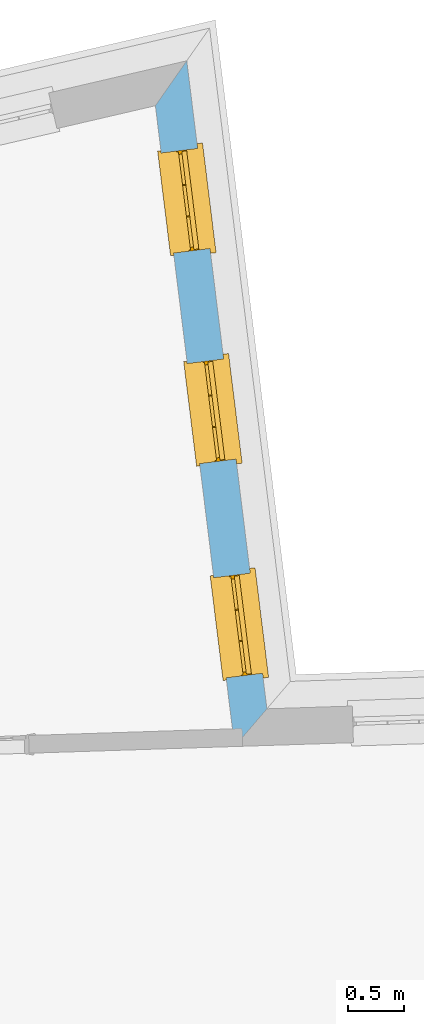
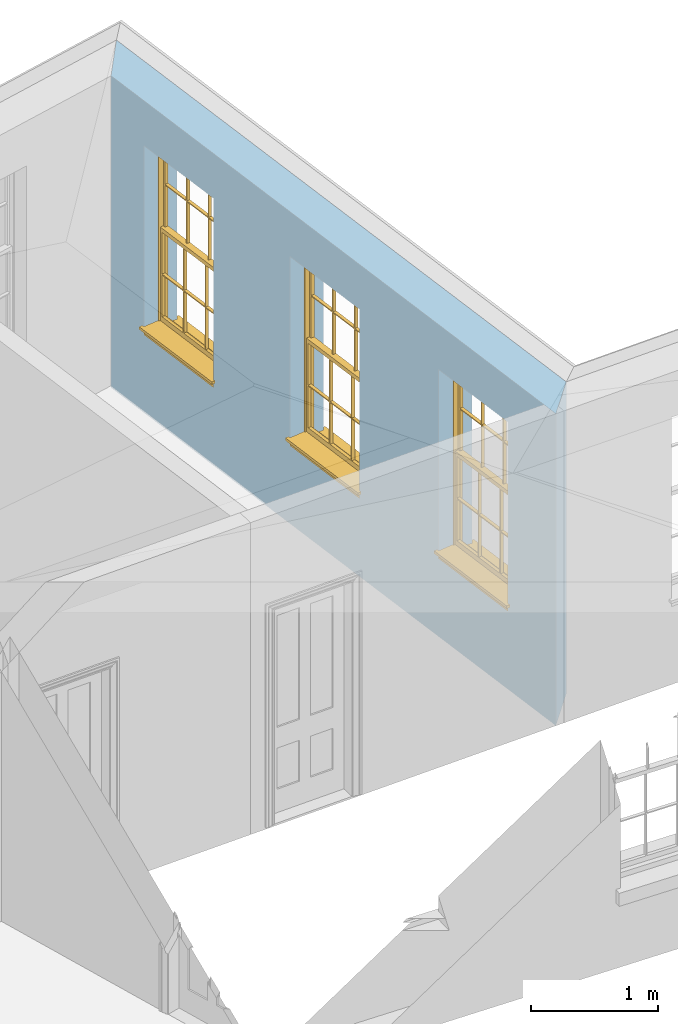
# One storey, part 9 of 11: 3 windows, 3 openings, plus 1 element that does not belong to this part.
"""IFC2X3 building model written with IfcOpenShell, lengths in metres."""

from ifc_helpers import new_model, si_unit, frame, origin, place, context, subcontext, project, spatial, polyline, outline, extrude, faceted_brep, material, layer, layer_set, layer_usage, element, fill, save


model = new_model("IFC2X3")

# Units and contexts
model_context = context("Model", 3, world=origin())
body_context = subcontext(model_context, "Body", "Model", "MODEL_VIEW")
ifc_project = project(units=[si_unit("PLANEANGLEUNIT", "RADIAN"), si_unit("MASSUNIT", "GRAM", prefix="KILO"), si_unit("FORCEUNIT", "NEWTON", prefix="KILO"), si_unit("LENGTHUNIT", "METRE")], contexts=[model_context])

# Site, building, storey
site_placement = place(None, origin())
site = spatial("IfcSite", under=ifc_project, at=site_placement, CompositionType="ELEMENT")
building_placement = place(None, origin())
building = spatial("IfcBuilding", under=site, at=building_placement, Name="Building plot-10", CompositionType="ELEMENT")
storey_placement = place(None, frame((0.0, 0.0, 4.6)))
storey = spatial("IfcBuildingStorey", under=building, at=storey_placement, Name="Floor 1", CompositionType="ELEMENT", Elevation=4.6)

# Wall, openings, windows
ifc_material = material(Name="Masonry")
ifc_layer = layer(ifc_material, 0.33, ventilated=False)
ifc_layer_set = layer_set([ifc_layer], Name="My Wall")
ifc_layer_usage = layer_usage(ifc_layer_set, "AXIS2", "NEGATIVE", 0.08)
wall_placement = place(storey_placement, origin())
wall = element("IfcWallStandardCase", 1, at=wall_placement, inside=storey, material=ifc_layer_usage, Name="exterior", context=body_context, shape_type="SweptSolid", body=[
    extrude(outline(polyline([(50.4938484504191, 20.0843374826447), (50.7843534970595, 20.4239768335759), (50.0623886340856, 26.2609056783057), (49.7798970152204, 25.8564795072323), (50.4938484504191, 20.0843374826447)])), origin(), (0.0, 0.0, 1.0), 3.0),
])
opening_1_placement = place(storey_placement, frame((0.0, 0.0, 0.75)))
opening_1 = element("IfcOpeningElement", 2, at=opening_1_placement, cuts=wall, Name="Opening", ObjectType="Opening", context=body_context, shape_type="SweptSolid", body=[
    extrude(outline(polyline([(50.7448686581057, 20.7432031661003), (50.6331627679987, 21.6463209846131), (50.3056585041424, 21.6058122552337), (50.4173643942494, 20.7026944367208), (50.7448686581057, 20.7432031661003)])), origin(), (0.0, 0.0, 1.0), 1.82),
])
opening_2_placement = place(storey_placement, frame((0.0, 0.0, 0.75)))
opening_2 = element("IfcOpeningElement", 3, at=opening_2_placement, cuts=wall, Name="Opening", ObjectType="Opening", context=body_context, shape_type="SweptSolid", body=[
    extrude(outline(polyline([(50.5062372966536, 22.6724858062268), (50.3945314065466, 23.5756036247397), (50.0670271426903, 23.5350948953602), (50.1787330327973, 22.6319770768474), (50.5062372966536, 22.6724858062268)])), origin(), (0.0, 0.0, 1.0), 1.82),
])
opening_3_placement = place(storey_placement, frame((0.0, 0.0, 0.75)))
opening_3 = element("IfcOpeningElement", 4, at=opening_3_placement, cuts=wall, Name="Opening", ObjectType="Opening", context=body_context, shape_type="SweptSolid", body=[
    extrude(outline(polyline([(50.2716577484948, 24.5690104173997), (50.1599518583878, 25.4721282359125), (49.8324475945315, 25.4316195065331), (49.9441534846385, 24.5285016880202), (50.2716577484948, 24.5690104173997)])), origin(), (0.0, 0.0, 1.0), 1.82),
])
window_1_placement = place(storey_placement, frame((50.4967593673055, 20.7125147347522, 0.75), z_axis=(0.0, 0.0, 1.0), x_axis=(-0.111705890107025, 0.903117818512843, 0.0)))
window_1 = element("IfcWindow", 5, at=window_1_placement, inside=storey, Name="bedroom outside window", OverallHeight=1.82, OverallWidth=0.91, context=body_context, shape_type="Brep", held_by="IfcProductRepresentation", body=[
    faceted_brep([(0.033125, -0.105, 0.975209), (0.01, -0.105, 0.975209), (0.033125, -0.105, 1.376042), (0.876875, -0.105, 0.975209), (0.876875, -0.105, 1.376042), (0.9, -0.105, 0.975209), (0.876875, -0.105, 1.386042), (0.876875, -0.105, 1.786875), (0.9, -0.105, 1.81), (0.033125, -0.105, 1.786875), (0.033125, -0.105, 1.386042), (0.01, -0.105, 1.81), (0.876875, -0.135, 1.376042), (0.876875, -0.135, 0.975209), (0.9, -0.135, 0.937083), (0.033125, -0.135, 1.786875), (0.01, -0.135, 1.81), (0.033125, -0.135, 1.386042), (0.01, -0.135, 0.937083), (0.033125, -0.135, 0.975209), (0.033125, -0.135, 1.376042), (0.876875, -0.135, 1.786875), (0.876875, -0.135, 1.386042), (0.9, -0.135, 1.81), (0.033125, -0.105, 0.937083), (0.01, -0.105, 0.937083), (0.033125, -0.105, 0.53625), (0.876875, -0.105, 0.937083), (0.876875, -0.105, 0.53625), (0.9, -0.105, 0.937083), (0.876875, -0.105, 0.52625), (0.876875, -0.105, 0.125417), (0.9, -0.105, 0.077167), (0.033125, -0.105, 0.125417), (0.033125, -0.105, 0.52625), (0.01, -0.105, 0.077167), (-0.0425, -0.25, 0.01), (-0.0425, -0.3, 0.001667), (0.0, -0.25, 0.01), (0.9525, -0.25, 0.01), (0.91, -0.25, 0.01), (0.9525, -0.3, 0.001667), (-0.02, 0.08, 0.077167), (0.0, 0.08, 0.077167), (-0.02, 0.11, 0.077167), (0.0, -0.06, 0.077167), (0.01, -0.06, 0.077167), (0.91, -0.06, 0.077167), (0.91, 0.08, 0.077167), (0.9, -0.06, 0.077167), (0.93, 0.08, 0.077167), (0.93, 0.11, 0.077167), (0.01, -0.075, 0.975209), (0.9, -0.075, 0.975209), (0.876875, -0.075, 0.125417), (0.876875, -0.075, 0.52625), (0.9, -0.075, 0.077167), (0.876875, -0.075, 0.53625), (0.876875, -0.075, 0.937083), (0.033125, -0.075, 0.125417), (0.01, -0.075, 0.077167), (0.033125, -0.075, 0.52625), (0.033125, -0.075, 0.937083), (0.033125, -0.075, 0.53625), (-0.02, 0.08, 0.052167), (-0.02, 0.11, 0.052167), (0.93, 0.11, 0.052167), (0.93, 0.08, 0.052167), (0.91, 0.08, 0.052167), (0.0, 0.08, 0.052167), (0.91, -0.15, 0.026667), (0.0, -0.15, 0.026667), (-0.0425, -0.3, -0.123333), (0.9525, -0.3, -0.123333), (-0.0425, -0.25, -0.123333), (0.9525, -0.25, -0.123333), (0.01, -0.06, 1.81), (0.9, -0.06, 1.81), (0.0, -0.06, 1.82), (0.91, -0.06, 1.82), (0.01, -0.15, 0.077167), (0.9, -0.15, 0.077167), (0.592292, -0.105, 0.125417), (0.592292, -0.075, 0.125417), (0.317708, -0.075, 0.125417), (0.317708, -0.105, 0.125417), (0.592292, -0.105, 0.53625), (0.317708, -0.105, 0.53625), (0.317708, -0.105, 0.52625), (0.592292, -0.105, 0.52625), (0.592292, -0.075, 0.53625), (0.317708, -0.075, 0.53625), (0.592292, -0.135, 1.386042), (0.592292, -0.105, 1.386042), (0.317708, -0.105, 1.386042), (0.317708, -0.135, 1.386042), (0.317708, -0.135, 1.376042), (0.592292, -0.135, 1.376042), (0.317708, -0.105, 1.376042), (0.592292, -0.105, 1.376042), (0.602292, -0.135, 1.376042), (0.592292, -0.135, 0.975209), (0.602292, -0.135, 0.975209), (0.602292, -0.105, 0.975209), (0.592292, -0.105, 0.975209), (0.602292, -0.105, 1.376042), (0.602292, -0.075, 0.53625), (0.602292, -0.105, 0.53625), (0.317708, -0.075, 0.52625), (0.307708, -0.075, 0.125417), (0.307708, -0.075, 0.52625), (0.602292, -0.075, 0.52625), (0.602292, -0.075, 0.125417), (0.592292, -0.075, 0.52625), (0.307708, -0.075, 0.53625), (0.317708, -0.075, 0.937083), (0.307708, -0.075, 0.937083), (0.602292, -0.075, 0.937083), (0.592292, -0.075, 0.937083), (0.307708, -0.105, 0.52625), (0.307708, -0.105, 0.125417), (0.307708, -0.105, 0.53625), (0.307708, -0.105, 0.937083), (0.592292, -0.105, 0.937083), (0.317708, -0.105, 0.937083), (0.602292, -0.105, 0.937083), (0.602292, -0.105, 0.52625), (0.602292, -0.105, 0.125417), (0.307708, -0.135, 1.386042), (0.307708, -0.135, 1.376042), (0.307708, -0.135, 0.975209), (0.317708, -0.135, 0.975209), (0.317708, -0.135, 1.786875), (0.307708, -0.135, 1.786875), (0.602292, -0.135, 1.786875), (0.592292, -0.135, 1.786875), (0.602292, -0.135, 1.386042), (0.602292, -0.105, 1.386042), (0.307708, -0.105, 1.386042), (0.307708, -0.105, 1.786875), (0.317708, -0.105, 1.786875), (0.592292, -0.105, 1.786875), (0.602292, -0.105, 1.786875), (0.307708, -0.105, 1.376042), (0.317708, -0.105, 0.975209), (0.307708, -0.105, 0.975209), (0.91, -0.15, 1.82), (0.9, -0.15, 1.81), (0.01, -0.15, 1.81), (0.0, -0.15, 1.82), (0.91, -0.25, 0.0), (0.0, -0.25, 0.0), (0.91, 0.08, 0.0), (0.0, 0.08, 0.0)], [[[0, 1, 2]], [[3, 4, 5]], [[6, 7, 8]], [[9, 10, 11]], [[12, 13, 14]], [[15, 16, 17]], [[18, 19, 20]], [[21, 22, 23]], [[24, 25, 26]], [[27, 28, 29]], [[30, 31, 32]], [[33, 34, 35]], [[14, 27, 29]], [[25, 24, 18]], [[36, 37, 38]], [[39, 40, 41]], [[42, 43, 44]], [[45, 46, 43]], [[47, 48, 49]], [[50, 51, 48]], [[1, 0, 52]], [[5, 53, 3]], [[54, 55, 56]], [[57, 58, 53]], [[59, 60, 61]], [[62, 63, 52]], [[48, 43, 46, 49]], [[51, 44, 43, 48]], [[64, 42, 44, 65]], [[65, 44, 51, 66]], [[66, 51, 50, 67]], [[65, 66, 68, 69]], [[60, 56, 49, 46]], [[70, 71, 38, 40]], [[37, 41, 40, 38]], [[37, 72, 73, 41]], [[74, 75, 73, 72]], [[8, 11, 76, 77]], [[76, 78, 79, 77]], [[32, 35, 80, 81]], [[81, 80, 71, 70]], [[82, 83, 84, 85]], [[86, 87, 88, 89]], [[86, 90, 91, 87]], [[92, 93, 94, 95]], [[92, 95, 96, 97]], [[96, 98, 99, 97]], [[100, 97, 101, 102]], [[103, 104, 99, 105]], [[97, 99, 104, 101]], [[102, 103, 105, 100]], [[28, 57, 106, 107]], [[108, 84, 109, 110]], [[111, 112, 83, 113]], [[114, 110, 61, 63]], [[90, 113, 108, 91]], [[115, 91, 114, 116]], [[117, 106, 90, 118]], [[111, 106, 57, 55]], [[119, 110, 109, 120]], [[34, 61, 110, 119]], [[89, 113, 83, 82]], [[88, 108, 113, 89]], [[85, 84, 108, 88]], [[121, 114, 63, 26]], [[122, 116, 114, 121]], [[123, 118, 90, 86]], [[87, 91, 115, 124]], [[107, 106, 117, 125]], [[126, 111, 55, 30]], [[127, 112, 111, 126]], [[126, 30, 28, 107]], [[88, 119, 120, 85]], [[126, 89, 82, 127]], [[125, 123, 86, 107]], [[121, 26, 34, 119]], [[124, 122, 121, 87]], [[128, 17, 20, 129]], [[96, 129, 130, 131]], [[132, 133, 128, 95]], [[134, 135, 92, 136]], [[100, 12, 22, 136]], [[137, 6, 4, 105]], [[94, 138, 139, 140]], [[137, 93, 141, 142]], [[99, 98, 94, 93]], [[143, 2, 10, 138]], [[144, 145, 143, 98]], [[129, 143, 145, 130]], [[20, 2, 143, 129]], [[131, 144, 98, 96]], [[128, 138, 10, 17]], [[133, 139, 138, 128]], [[135, 141, 93, 92]], [[95, 94, 140, 132]], [[22, 6, 137, 136]], [[136, 137, 142, 134]], [[100, 105, 4, 12]], [[107, 86, 89, 126]], [[106, 111, 113, 90]], [[91, 108, 110, 114]], [[87, 121, 119, 88]], [[97, 100, 136, 92]], [[129, 96, 95, 128]], [[98, 143, 138, 94]], [[105, 99, 93, 137]], [[131, 101, 104, 144]], [[124, 115, 118, 123]], [[132, 140, 141, 135]], [[120, 109, 59, 33]], [[15, 9, 139, 133]], [[134, 142, 7, 21]], [[31, 54, 112, 127]], [[36, 74, 72, 37]], [[39, 41, 73, 75]], [[18, 14, 101, 131]], [[23, 16, 132, 135]], [[83, 56, 60, 84]], [[52, 53, 118, 115]], [[53, 52, 144, 104]], [[11, 8, 141, 140]], [[14, 18, 124, 123]], [[2, 1, 11, 10]], [[8, 5, 4, 6]], [[57, 53, 56, 55]], [[60, 52, 63, 61]], [[26, 25, 35, 34]], [[32, 29, 28, 30]], [[14, 23, 22, 12]], [[18, 20, 17, 16]], [[19, 0, 2, 20]], [[17, 10, 9, 15]], [[12, 4, 3, 13]], [[21, 7, 6, 22]], [[27, 58, 57, 28]], [[30, 55, 54, 31]], [[33, 59, 61, 34]], [[26, 63, 62, 24]], [[5, 8, 77, 53]], [[76, 11, 1, 52]], [[46, 45, 78, 76]], [[49, 77, 79, 47]], [[70, 146, 147, 81]], [[71, 80, 148, 149]], [[19, 130, 145, 0]], [[102, 13, 3, 103]], [[116, 122, 24, 62]], [[29, 32, 81, 14]], [[80, 35, 25, 18]], [[60, 46, 76, 52]], [[77, 49, 56, 53]], [[23, 14, 81, 147]], [[16, 148, 80, 18]], [[35, 85, 120]], [[120, 33, 35]], [[127, 82, 32]], [[32, 31, 127]], [[32, 82, 85, 35]], [[102, 101, 14]], [[14, 13, 102]], [[18, 131, 130]], [[130, 19, 18]], [[134, 21, 23]], [[23, 135, 134]], [[16, 15, 133]], [[133, 132, 16]], [[11, 140, 139]], [[139, 9, 11]], [[142, 141, 8]], [[8, 7, 142]], [[23, 147, 148, 16]], [[146, 149, 148, 147]], [[52, 115, 116]], [[116, 62, 52]], [[118, 53, 117]], [[58, 117, 53]], [[27, 125, 117, 58]], [[56, 83, 112]], [[112, 54, 56]], [[109, 84, 60]], [[60, 59, 109]], [[125, 27, 14]], [[14, 123, 125]], [[122, 124, 18]], [[18, 24, 122]], [[145, 144, 52]], [[52, 0, 145]], [[103, 3, 53]], [[53, 104, 103]], [[79, 78, 149, 146]], [[78, 45, 71, 149]], [[146, 70, 47, 79]], [[150, 75, 74, 151]], [[68, 66, 67]], [[48, 68, 67, 50]], [[69, 64, 65]], [[42, 64, 69, 43]], [[69, 68, 152, 153]], [[70, 68, 48, 47]], [[150, 152, 68, 70]], [[43, 69, 71, 45]], [[69, 153, 151, 71]], [[152, 150, 151, 153]], [[38, 151, 74, 36]], [[71, 151, 38]], [[39, 75, 150, 40]], [[40, 150, 70]]]),
])
fill(opening_1, window_1)
window_2_placement = place(storey_placement, frame((50.2581280058534, 22.6417973748787, 0.75), z_axis=(0.0, 0.0, 1.0), x_axis=(-0.111705890107025, 0.903117818512843, 0.0)))
window_2 = element("IfcWindow", 6, at=window_2_placement, inside=storey, Name="bedroom outside window", OverallHeight=1.82, OverallWidth=0.91, context=body_context, shape_type="Brep", held_by="IfcProductRepresentation", body=[
    faceted_brep([(0.033125, -0.105, 0.975209), (0.01, -0.105, 0.975209), (0.033125, -0.105, 1.376042), (0.876875, -0.105, 0.975209), (0.876875, -0.105, 1.376042), (0.9, -0.105, 0.975209), (0.876875, -0.105, 1.386042), (0.876875, -0.105, 1.786875), (0.9, -0.105, 1.81), (0.033125, -0.105, 1.786875), (0.033125, -0.105, 1.386042), (0.01, -0.105, 1.81), (0.876875, -0.135, 1.376042), (0.876875, -0.135, 0.975209), (0.9, -0.135, 0.937083), (0.033125, -0.135, 1.786875), (0.01, -0.135, 1.81), (0.033125, -0.135, 1.386042), (0.01, -0.135, 0.937083), (0.033125, -0.135, 0.975209), (0.033125, -0.135, 1.376042), (0.876875, -0.135, 1.786875), (0.876875, -0.135, 1.386042), (0.9, -0.135, 1.81), (0.033125, -0.105, 0.937083), (0.01, -0.105, 0.937083), (0.033125, -0.105, 0.53625), (0.876875, -0.105, 0.937083), (0.876875, -0.105, 0.53625), (0.9, -0.105, 0.937083), (0.876875, -0.105, 0.52625), (0.876875, -0.105, 0.125417), (0.9, -0.105, 0.077167), (0.033125, -0.105, 0.125417), (0.033125, -0.105, 0.52625), (0.01, -0.105, 0.077167), (-0.0425, -0.25, 0.01), (-0.0425, -0.3, 0.001667), (0.0, -0.25, 0.01), (0.9525, -0.25, 0.01), (0.91, -0.25, 0.01), (0.9525, -0.3, 0.001667), (-0.02, 0.08, 0.077167), (0.0, 0.08, 0.077167), (-0.02, 0.11, 0.077167), (0.0, -0.06, 0.077167), (0.01, -0.06, 0.077167), (0.91, -0.06, 0.077167), (0.91, 0.08, 0.077167), (0.9, -0.06, 0.077167), (0.93, 0.08, 0.077167), (0.93, 0.11, 0.077167), (0.01, -0.075, 0.975209), (0.9, -0.075, 0.975209), (0.876875, -0.075, 0.125417), (0.876875, -0.075, 0.52625), (0.9, -0.075, 0.077167), (0.876875, -0.075, 0.53625), (0.876875, -0.075, 0.937083), (0.033125, -0.075, 0.125417), (0.01, -0.075, 0.077167), (0.033125, -0.075, 0.52625), (0.033125, -0.075, 0.937083), (0.033125, -0.075, 0.53625), (-0.02, 0.08, 0.052167), (-0.02, 0.11, 0.052167), (0.93, 0.11, 0.052167), (0.93, 0.08, 0.052167), (0.91, 0.08, 0.052167), (0.0, 0.08, 0.052167), (0.91, -0.15, 0.026667), (0.0, -0.15, 0.026667), (-0.0425, -0.3, -0.123333), (0.9525, -0.3, -0.123333), (-0.0425, -0.25, -0.123333), (0.9525, -0.25, -0.123333), (0.01, -0.06, 1.81), (0.9, -0.06, 1.81), (0.0, -0.06, 1.82), (0.91, -0.06, 1.82), (0.01, -0.15, 0.077167), (0.9, -0.15, 0.077167), (0.592292, -0.105, 0.125417), (0.592292, -0.075, 0.125417), (0.317708, -0.075, 0.125417), (0.317708, -0.105, 0.125417), (0.592292, -0.105, 0.53625), (0.317708, -0.105, 0.53625), (0.317708, -0.105, 0.52625), (0.592292, -0.105, 0.52625), (0.592292, -0.075, 0.53625), (0.317708, -0.075, 0.53625), (0.592292, -0.135, 1.386042), (0.592292, -0.105, 1.386042), (0.317708, -0.105, 1.386042), (0.317708, -0.135, 1.386042), (0.317708, -0.135, 1.376042), (0.592292, -0.135, 1.376042), (0.317708, -0.105, 1.376042), (0.592292, -0.105, 1.376042), (0.602292, -0.135, 1.376042), (0.592292, -0.135, 0.975209), (0.602292, -0.135, 0.975209), (0.602292, -0.105, 0.975209), (0.592292, -0.105, 0.975209), (0.602292, -0.105, 1.376042), (0.602292, -0.075, 0.53625), (0.602292, -0.105, 0.53625), (0.317708, -0.075, 0.52625), (0.307708, -0.075, 0.125417), (0.307708, -0.075, 0.52625), (0.602292, -0.075, 0.52625), (0.602292, -0.075, 0.125417), (0.592292, -0.075, 0.52625), (0.307708, -0.075, 0.53625), (0.317708, -0.075, 0.937083), (0.307708, -0.075, 0.937083), (0.602292, -0.075, 0.937083), (0.592292, -0.075, 0.937083), (0.307708, -0.105, 0.52625), (0.307708, -0.105, 0.125417), (0.307708, -0.105, 0.53625), (0.307708, -0.105, 0.937083), (0.592292, -0.105, 0.937083), (0.317708, -0.105, 0.937083), (0.602292, -0.105, 0.937083), (0.602292, -0.105, 0.52625), (0.602292, -0.105, 0.125417), (0.307708, -0.135, 1.386042), (0.307708, -0.135, 1.376042), (0.307708, -0.135, 0.975209), (0.317708, -0.135, 0.975209), (0.317708, -0.135, 1.786875), (0.307708, -0.135, 1.786875), (0.602292, -0.135, 1.786875), (0.592292, -0.135, 1.786875), (0.602292, -0.135, 1.386042), (0.602292, -0.105, 1.386042), (0.307708, -0.105, 1.386042), (0.307708, -0.105, 1.786875), (0.317708, -0.105, 1.786875), (0.592292, -0.105, 1.786875), (0.602292, -0.105, 1.786875), (0.307708, -0.105, 1.376042), (0.317708, -0.105, 0.975209), (0.307708, -0.105, 0.975209), (0.91, -0.15, 1.82), (0.9, -0.15, 1.81), (0.01, -0.15, 1.81), (0.0, -0.15, 1.82), (0.91, -0.25, 0.0), (0.0, -0.25, 0.0), (0.91, 0.08, 0.0), (0.0, 0.08, 0.0)], [[[0, 1, 2]], [[3, 4, 5]], [[6, 7, 8]], [[9, 10, 11]], [[12, 13, 14]], [[15, 16, 17]], [[18, 19, 20]], [[21, 22, 23]], [[24, 25, 26]], [[27, 28, 29]], [[30, 31, 32]], [[33, 34, 35]], [[14, 27, 29]], [[25, 24, 18]], [[36, 37, 38]], [[39, 40, 41]], [[42, 43, 44]], [[45, 46, 43]], [[47, 48, 49]], [[50, 51, 48]], [[1, 0, 52]], [[5, 53, 3]], [[54, 55, 56]], [[57, 58, 53]], [[59, 60, 61]], [[62, 63, 52]], [[48, 43, 46, 49]], [[51, 44, 43, 48]], [[64, 42, 44, 65]], [[65, 44, 51, 66]], [[66, 51, 50, 67]], [[65, 66, 68, 69]], [[60, 56, 49, 46]], [[70, 71, 38, 40]], [[37, 41, 40, 38]], [[37, 72, 73, 41]], [[74, 75, 73, 72]], [[8, 11, 76, 77]], [[76, 78, 79, 77]], [[32, 35, 80, 81]], [[81, 80, 71, 70]], [[82, 83, 84, 85]], [[86, 87, 88, 89]], [[86, 90, 91, 87]], [[92, 93, 94, 95]], [[92, 95, 96, 97]], [[96, 98, 99, 97]], [[100, 97, 101, 102]], [[103, 104, 99, 105]], [[97, 99, 104, 101]], [[102, 103, 105, 100]], [[28, 57, 106, 107]], [[108, 84, 109, 110]], [[111, 112, 83, 113]], [[114, 110, 61, 63]], [[90, 113, 108, 91]], [[115, 91, 114, 116]], [[117, 106, 90, 118]], [[111, 106, 57, 55]], [[119, 110, 109, 120]], [[34, 61, 110, 119]], [[89, 113, 83, 82]], [[88, 108, 113, 89]], [[85, 84, 108, 88]], [[121, 114, 63, 26]], [[122, 116, 114, 121]], [[123, 118, 90, 86]], [[87, 91, 115, 124]], [[107, 106, 117, 125]], [[126, 111, 55, 30]], [[127, 112, 111, 126]], [[126, 30, 28, 107]], [[88, 119, 120, 85]], [[126, 89, 82, 127]], [[125, 123, 86, 107]], [[121, 26, 34, 119]], [[124, 122, 121, 87]], [[128, 17, 20, 129]], [[96, 129, 130, 131]], [[132, 133, 128, 95]], [[134, 135, 92, 136]], [[100, 12, 22, 136]], [[137, 6, 4, 105]], [[94, 138, 139, 140]], [[137, 93, 141, 142]], [[99, 98, 94, 93]], [[143, 2, 10, 138]], [[144, 145, 143, 98]], [[129, 143, 145, 130]], [[20, 2, 143, 129]], [[131, 144, 98, 96]], [[128, 138, 10, 17]], [[133, 139, 138, 128]], [[135, 141, 93, 92]], [[95, 94, 140, 132]], [[22, 6, 137, 136]], [[136, 137, 142, 134]], [[100, 105, 4, 12]], [[107, 86, 89, 126]], [[106, 111, 113, 90]], [[91, 108, 110, 114]], [[87, 121, 119, 88]], [[97, 100, 136, 92]], [[129, 96, 95, 128]], [[98, 143, 138, 94]], [[105, 99, 93, 137]], [[131, 101, 104, 144]], [[124, 115, 118, 123]], [[132, 140, 141, 135]], [[120, 109, 59, 33]], [[15, 9, 139, 133]], [[134, 142, 7, 21]], [[31, 54, 112, 127]], [[36, 74, 72, 37]], [[39, 41, 73, 75]], [[18, 14, 101, 131]], [[23, 16, 132, 135]], [[83, 56, 60, 84]], [[52, 53, 118, 115]], [[53, 52, 144, 104]], [[11, 8, 141, 140]], [[14, 18, 124, 123]], [[2, 1, 11, 10]], [[8, 5, 4, 6]], [[57, 53, 56, 55]], [[60, 52, 63, 61]], [[26, 25, 35, 34]], [[32, 29, 28, 30]], [[14, 23, 22, 12]], [[18, 20, 17, 16]], [[19, 0, 2, 20]], [[17, 10, 9, 15]], [[12, 4, 3, 13]], [[21, 7, 6, 22]], [[27, 58, 57, 28]], [[30, 55, 54, 31]], [[33, 59, 61, 34]], [[26, 63, 62, 24]], [[5, 8, 77, 53]], [[76, 11, 1, 52]], [[46, 45, 78, 76]], [[49, 77, 79, 47]], [[70, 146, 147, 81]], [[71, 80, 148, 149]], [[19, 130, 145, 0]], [[102, 13, 3, 103]], [[116, 122, 24, 62]], [[29, 32, 81, 14]], [[80, 35, 25, 18]], [[60, 46, 76, 52]], [[77, 49, 56, 53]], [[23, 14, 81, 147]], [[16, 148, 80, 18]], [[35, 85, 120]], [[120, 33, 35]], [[127, 82, 32]], [[32, 31, 127]], [[32, 82, 85, 35]], [[102, 101, 14]], [[14, 13, 102]], [[18, 131, 130]], [[130, 19, 18]], [[134, 21, 23]], [[23, 135, 134]], [[16, 15, 133]], [[133, 132, 16]], [[11, 140, 139]], [[139, 9, 11]], [[142, 141, 8]], [[8, 7, 142]], [[23, 147, 148, 16]], [[146, 149, 148, 147]], [[52, 115, 116]], [[116, 62, 52]], [[118, 53, 117]], [[58, 117, 53]], [[27, 125, 117, 58]], [[56, 83, 112]], [[112, 54, 56]], [[109, 84, 60]], [[60, 59, 109]], [[125, 27, 14]], [[14, 123, 125]], [[122, 124, 18]], [[18, 24, 122]], [[145, 144, 52]], [[52, 0, 145]], [[103, 3, 53]], [[53, 104, 103]], [[79, 78, 149, 146]], [[78, 45, 71, 149]], [[146, 70, 47, 79]], [[150, 75, 74, 151]], [[68, 66, 67]], [[48, 68, 67, 50]], [[69, 64, 65]], [[42, 64, 69, 43]], [[69, 68, 152, 153]], [[70, 68, 48, 47]], [[150, 152, 68, 70]], [[43, 69, 71, 45]], [[69, 153, 151, 71]], [[152, 150, 151, 153]], [[38, 151, 74, 36]], [[71, 151, 38]], [[39, 75, 150, 40]], [[40, 150, 70]]]),
])
fill(opening_2, window_2)
window_3_placement = place(storey_placement, frame((50.0235484576946, 24.5383219860516, 0.75), z_axis=(0.0, 0.0, 1.0), x_axis=(-0.111705890107025, 0.903117818512843, 0.0)))
window_3 = element("IfcWindow", 7, at=window_3_placement, inside=storey, Name="bedroom outside window", OverallHeight=1.82, OverallWidth=0.91, context=body_context, shape_type="Brep", held_by="IfcProductRepresentation", body=[
    faceted_brep([(0.033125, -0.105, 0.975209), (0.01, -0.105, 0.975209), (0.033125, -0.105, 1.376042), (0.876875, -0.105, 0.975209), (0.876875, -0.105, 1.376042), (0.9, -0.105, 0.975209), (0.876875, -0.105, 1.386042), (0.876875, -0.105, 1.786875), (0.9, -0.105, 1.81), (0.033125, -0.105, 1.786875), (0.033125, -0.105, 1.386042), (0.01, -0.105, 1.81), (0.876875, -0.135, 1.376042), (0.876875, -0.135, 0.975209), (0.9, -0.135, 0.937083), (0.033125, -0.135, 1.786875), (0.01, -0.135, 1.81), (0.033125, -0.135, 1.386042), (0.01, -0.135, 0.937083), (0.033125, -0.135, 0.975209), (0.033125, -0.135, 1.376042), (0.876875, -0.135, 1.786875), (0.876875, -0.135, 1.386042), (0.9, -0.135, 1.81), (0.033125, -0.105, 0.937083), (0.01, -0.105, 0.937083), (0.033125, -0.105, 0.53625), (0.876875, -0.105, 0.937083), (0.876875, -0.105, 0.53625), (0.9, -0.105, 0.937083), (0.876875, -0.105, 0.52625), (0.876875, -0.105, 0.125417), (0.9, -0.105, 0.077167), (0.033125, -0.105, 0.125417), (0.033125, -0.105, 0.52625), (0.01, -0.105, 0.077167), (-0.0425, -0.25, 0.01), (-0.0425, -0.3, 0.001667), (0.0, -0.25, 0.01), (0.9525, -0.25, 0.01), (0.91, -0.25, 0.01), (0.9525, -0.3, 0.001667), (-0.02, 0.08, 0.077167), (0.0, 0.08, 0.077167), (-0.02, 0.11, 0.077167), (0.0, -0.06, 0.077167), (0.01, -0.06, 0.077167), (0.91, -0.06, 0.077167), (0.91, 0.08, 0.077167), (0.9, -0.06, 0.077167), (0.93, 0.08, 0.077167), (0.93, 0.11, 0.077167), (0.01, -0.075, 0.975209), (0.9, -0.075, 0.975209), (0.876875, -0.075, 0.125417), (0.876875, -0.075, 0.52625), (0.9, -0.075, 0.077167), (0.876875, -0.075, 0.53625), (0.876875, -0.075, 0.937083), (0.033125, -0.075, 0.125417), (0.01, -0.075, 0.077167), (0.033125, -0.075, 0.52625), (0.033125, -0.075, 0.937083), (0.033125, -0.075, 0.53625), (-0.02, 0.08, 0.052167), (-0.02, 0.11, 0.052167), (0.93, 0.11, 0.052167), (0.93, 0.08, 0.052167), (0.91, 0.08, 0.052167), (0.0, 0.08, 0.052167), (0.91, -0.15, 0.026667), (0.0, -0.15, 0.026667), (-0.0425, -0.3, -0.123333), (0.9525, -0.3, -0.123333), (-0.0425, -0.25, -0.123333), (0.9525, -0.25, -0.123333), (0.01, -0.06, 1.81), (0.9, -0.06, 1.81), (0.0, -0.06, 1.82), (0.91, -0.06, 1.82), (0.01, -0.15, 0.077167), (0.9, -0.15, 0.077167), (0.592292, -0.105, 0.125417), (0.592292, -0.075, 0.125417), (0.317708, -0.075, 0.125417), (0.317708, -0.105, 0.125417), (0.592292, -0.105, 0.53625), (0.317708, -0.105, 0.53625), (0.317708, -0.105, 0.52625), (0.592292, -0.105, 0.52625), (0.592292, -0.075, 0.53625), (0.317708, -0.075, 0.53625), (0.592292, -0.135, 1.386042), (0.592292, -0.105, 1.386042), (0.317708, -0.105, 1.386042), (0.317708, -0.135, 1.386042), (0.317708, -0.135, 1.376042), (0.592292, -0.135, 1.376042), (0.317708, -0.105, 1.376042), (0.592292, -0.105, 1.376042), (0.602292, -0.135, 1.376042), (0.592292, -0.135, 0.975209), (0.602292, -0.135, 0.975209), (0.602292, -0.105, 0.975209), (0.592292, -0.105, 0.975209), (0.602292, -0.105, 1.376042), (0.602292, -0.075, 0.53625), (0.602292, -0.105, 0.53625), (0.317708, -0.075, 0.52625), (0.307708, -0.075, 0.125417), (0.307708, -0.075, 0.52625), (0.602292, -0.075, 0.52625), (0.602292, -0.075, 0.125417), (0.592292, -0.075, 0.52625), (0.307708, -0.075, 0.53625), (0.317708, -0.075, 0.937083), (0.307708, -0.075, 0.937083), (0.602292, -0.075, 0.937083), (0.592292, -0.075, 0.937083), (0.307708, -0.105, 0.52625), (0.307708, -0.105, 0.125417), (0.307708, -0.105, 0.53625), (0.307708, -0.105, 0.937083), (0.592292, -0.105, 0.937083), (0.317708, -0.105, 0.937083), (0.602292, -0.105, 0.937083), (0.602292, -0.105, 0.52625), (0.602292, -0.105, 0.125417), (0.307708, -0.135, 1.386042), (0.307708, -0.135, 1.376042), (0.307708, -0.135, 0.975209), (0.317708, -0.135, 0.975209), (0.317708, -0.135, 1.786875), (0.307708, -0.135, 1.786875), (0.602292, -0.135, 1.786875), (0.592292, -0.135, 1.786875), (0.602292, -0.135, 1.386042), (0.602292, -0.105, 1.386042), (0.307708, -0.105, 1.386042), (0.307708, -0.105, 1.786875), (0.317708, -0.105, 1.786875), (0.592292, -0.105, 1.786875), (0.602292, -0.105, 1.786875), (0.307708, -0.105, 1.376042), (0.317708, -0.105, 0.975209), (0.307708, -0.105, 0.975209), (0.91, -0.15, 1.82), (0.9, -0.15, 1.81), (0.01, -0.15, 1.81), (0.0, -0.15, 1.82), (0.91, -0.25, 0.0), (0.0, -0.25, 0.0), (0.91, 0.08, 0.0), (0.0, 0.08, 0.0)], [[[0, 1, 2]], [[3, 4, 5]], [[6, 7, 8]], [[9, 10, 11]], [[12, 13, 14]], [[15, 16, 17]], [[18, 19, 20]], [[21, 22, 23]], [[24, 25, 26]], [[27, 28, 29]], [[30, 31, 32]], [[33, 34, 35]], [[14, 27, 29]], [[25, 24, 18]], [[36, 37, 38]], [[39, 40, 41]], [[42, 43, 44]], [[45, 46, 43]], [[47, 48, 49]], [[50, 51, 48]], [[1, 0, 52]], [[5, 53, 3]], [[54, 55, 56]], [[57, 58, 53]], [[59, 60, 61]], [[62, 63, 52]], [[48, 43, 46, 49]], [[51, 44, 43, 48]], [[64, 42, 44, 65]], [[65, 44, 51, 66]], [[66, 51, 50, 67]], [[65, 66, 68, 69]], [[60, 56, 49, 46]], [[70, 71, 38, 40]], [[37, 41, 40, 38]], [[37, 72, 73, 41]], [[74, 75, 73, 72]], [[8, 11, 76, 77]], [[76, 78, 79, 77]], [[32, 35, 80, 81]], [[81, 80, 71, 70]], [[82, 83, 84, 85]], [[86, 87, 88, 89]], [[86, 90, 91, 87]], [[92, 93, 94, 95]], [[92, 95, 96, 97]], [[96, 98, 99, 97]], [[100, 97, 101, 102]], [[103, 104, 99, 105]], [[97, 99, 104, 101]], [[102, 103, 105, 100]], [[28, 57, 106, 107]], [[108, 84, 109, 110]], [[111, 112, 83, 113]], [[114, 110, 61, 63]], [[90, 113, 108, 91]], [[115, 91, 114, 116]], [[117, 106, 90, 118]], [[111, 106, 57, 55]], [[119, 110, 109, 120]], [[34, 61, 110, 119]], [[89, 113, 83, 82]], [[88, 108, 113, 89]], [[85, 84, 108, 88]], [[121, 114, 63, 26]], [[122, 116, 114, 121]], [[123, 118, 90, 86]], [[87, 91, 115, 124]], [[107, 106, 117, 125]], [[126, 111, 55, 30]], [[127, 112, 111, 126]], [[126, 30, 28, 107]], [[88, 119, 120, 85]], [[126, 89, 82, 127]], [[125, 123, 86, 107]], [[121, 26, 34, 119]], [[124, 122, 121, 87]], [[128, 17, 20, 129]], [[96, 129, 130, 131]], [[132, 133, 128, 95]], [[134, 135, 92, 136]], [[100, 12, 22, 136]], [[137, 6, 4, 105]], [[94, 138, 139, 140]], [[137, 93, 141, 142]], [[99, 98, 94, 93]], [[143, 2, 10, 138]], [[144, 145, 143, 98]], [[129, 143, 145, 130]], [[20, 2, 143, 129]], [[131, 144, 98, 96]], [[128, 138, 10, 17]], [[133, 139, 138, 128]], [[135, 141, 93, 92]], [[95, 94, 140, 132]], [[22, 6, 137, 136]], [[136, 137, 142, 134]], [[100, 105, 4, 12]], [[107, 86, 89, 126]], [[106, 111, 113, 90]], [[91, 108, 110, 114]], [[87, 121, 119, 88]], [[97, 100, 136, 92]], [[129, 96, 95, 128]], [[98, 143, 138, 94]], [[105, 99, 93, 137]], [[131, 101, 104, 144]], [[124, 115, 118, 123]], [[132, 140, 141, 135]], [[120, 109, 59, 33]], [[15, 9, 139, 133]], [[134, 142, 7, 21]], [[31, 54, 112, 127]], [[36, 74, 72, 37]], [[39, 41, 73, 75]], [[18, 14, 101, 131]], [[23, 16, 132, 135]], [[83, 56, 60, 84]], [[52, 53, 118, 115]], [[53, 52, 144, 104]], [[11, 8, 141, 140]], [[14, 18, 124, 123]], [[2, 1, 11, 10]], [[8, 5, 4, 6]], [[57, 53, 56, 55]], [[60, 52, 63, 61]], [[26, 25, 35, 34]], [[32, 29, 28, 30]], [[14, 23, 22, 12]], [[18, 20, 17, 16]], [[19, 0, 2, 20]], [[17, 10, 9, 15]], [[12, 4, 3, 13]], [[21, 7, 6, 22]], [[27, 58, 57, 28]], [[30, 55, 54, 31]], [[33, 59, 61, 34]], [[26, 63, 62, 24]], [[5, 8, 77, 53]], [[76, 11, 1, 52]], [[46, 45, 78, 76]], [[49, 77, 79, 47]], [[70, 146, 147, 81]], [[71, 80, 148, 149]], [[19, 130, 145, 0]], [[102, 13, 3, 103]], [[116, 122, 24, 62]], [[29, 32, 81, 14]], [[80, 35, 25, 18]], [[60, 46, 76, 52]], [[77, 49, 56, 53]], [[23, 14, 81, 147]], [[16, 148, 80, 18]], [[35, 85, 120]], [[120, 33, 35]], [[127, 82, 32]], [[32, 31, 127]], [[32, 82, 85, 35]], [[102, 101, 14]], [[14, 13, 102]], [[18, 131, 130]], [[130, 19, 18]], [[134, 21, 23]], [[23, 135, 134]], [[16, 15, 133]], [[133, 132, 16]], [[11, 140, 139]], [[139, 9, 11]], [[142, 141, 8]], [[8, 7, 142]], [[23, 147, 148, 16]], [[146, 149, 148, 147]], [[52, 115, 116]], [[116, 62, 52]], [[118, 53, 117]], [[58, 117, 53]], [[27, 125, 117, 58]], [[56, 83, 112]], [[112, 54, 56]], [[109, 84, 60]], [[60, 59, 109]], [[125, 27, 14]], [[14, 123, 125]], [[122, 124, 18]], [[18, 24, 122]], [[145, 144, 52]], [[52, 0, 145]], [[103, 3, 53]], [[53, 104, 103]], [[79, 78, 149, 146]], [[78, 45, 71, 149]], [[146, 70, 47, 79]], [[150, 75, 74, 151]], [[68, 66, 67]], [[48, 68, 67, 50]], [[69, 64, 65]], [[42, 64, 69, 43]], [[69, 68, 152, 153]], [[70, 68, 48, 47]], [[150, 152, 68, 70]], [[43, 69, 71, 45]], [[69, 153, 151, 71]], [[152, 150, 151, 153]], [[38, 151, 74, 36]], [[71, 151, 38]], [[39, 75, 150, 40]], [[40, 150, 70]]]),
])
fill(opening_3, window_3)

save(model, "model.ifc")
